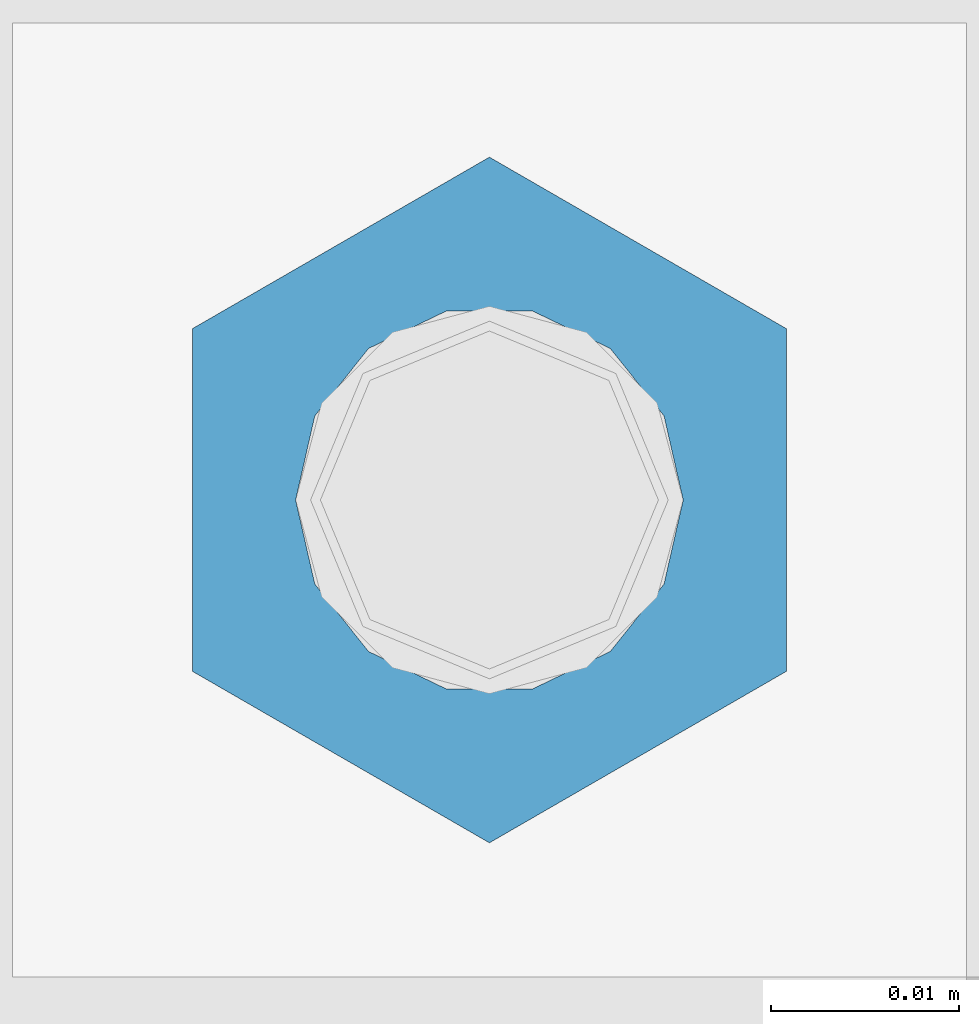
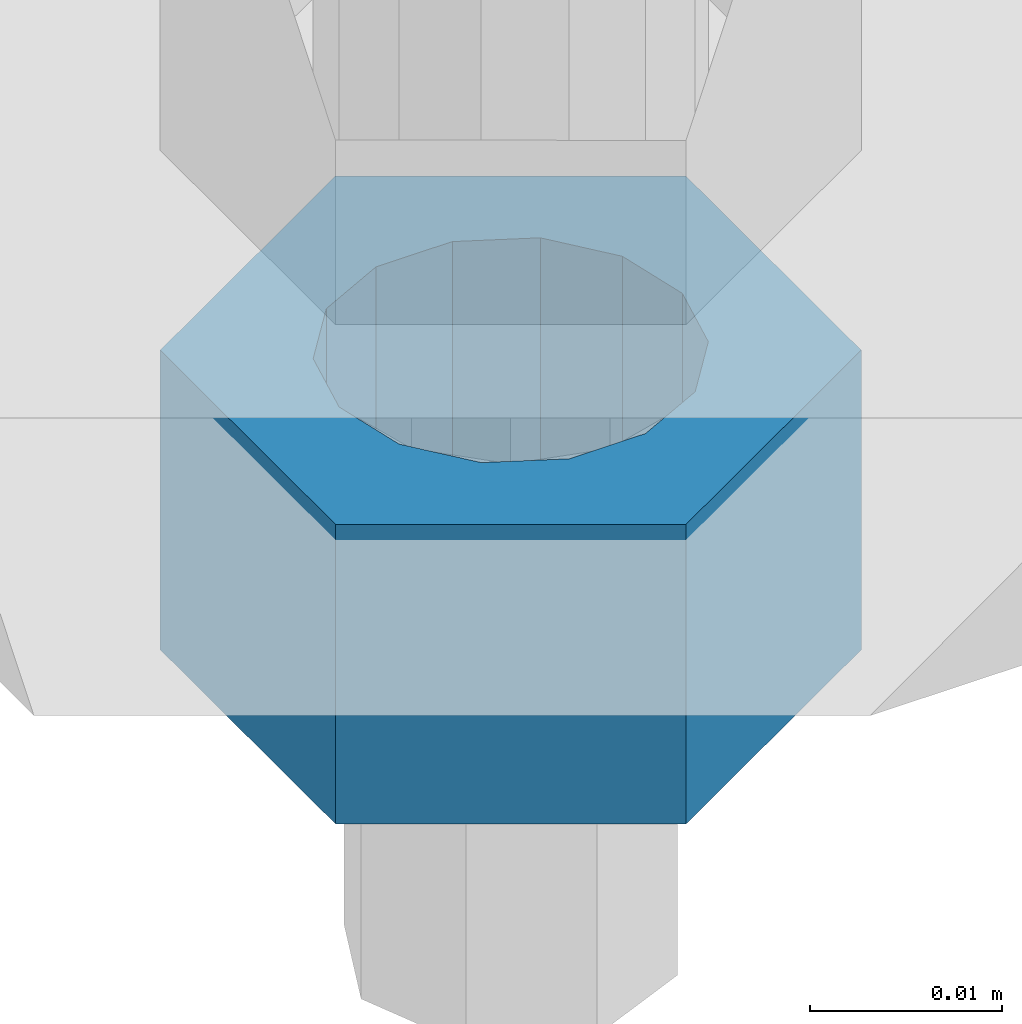
# One storey, part 1683 of 3843: 1 column, 1 element without a shape of its own.
"""IFC2X3 building model written with IfcOpenShell, lengths in millimetres."""

import ifcopenshell
import ifcopenshell.guid

model = None  # the IFC model being written
_history = None  # IfcOwnerHistory: only IFC2X3 demands one
_inside = {}  # id of a spatial element -> (the spatial element, [elements in it])
_under = {}  # id of a project, library or spatial element -> (it, [spatial elements below it])
_declared = {}  # id of a project -> (the project, [libraries it declares])
_typed = {}  # id of a type object -> (the type object, [elements of that type])
_made_of = {}  # id of a material, layer set ... -> (it, [elements and type objects made of it])


def new_model(schema):
    """Start an empty IFC model of exactly this schema.

    Asked for "IFC4X3", IfcOpenShell would pick the latest addendum, in which some entities
    have other attributes; the version numbers below select the first issue.
    IFC2X3 requires an IfcOwnerHistory on every rooted entity: one is made here for all.
    """
    global model, _history
    if schema == "IFC4X3":
        model = ifcopenshell.file(schema_version=(4, 3, 0, 0))
    else:
        model = ifcopenshell.file(schema=schema)
    _inside.clear()
    _under.clear()
    _declared.clear()
    _typed.clear()
    _made_of.clear()
    _history = None
    if model.schema == "IFC2X3":
        org = make("IfcOrganization", Name="unknown")
        user = make(
            "IfcPersonAndOrganization",
            ThePerson=make("IfcPerson", FamilyName="unknown"),
            TheOrganization=org,
        )
        app = make(
            "IfcApplication",
            ApplicationDeveloper=org,
            Version="unknown",
            ApplicationFullName="unknown",
            ApplicationIdentifier="unknown",
        )
        _history = make(
            "IfcOwnerHistory",
            OwningUser=user,
            OwningApplication=app,
            ChangeAction="ADDED",
            CreationDate=0,
        )
    return model


def make(cls, **values):
    """One entity of the class cls with the attributes given. An attribute that is None is left unset."""
    return model.create_entity(
        cls, **{name: value for name, value in values.items() if value is not None}
    )


def rooted(cls, **values):
    """An entity with a GlobalId (a new one), such as an element, a storey or a relation."""
    return make(cls, GlobalId=ifcopenshell.guid.new(), OwnerHistory=_history, **values)


def si_unit(unit_type, name, prefix=None):
    """IfcSIUnit, for example si_unit("LENGTHUNIT", "METRE", prefix="MILLI")."""
    return make("IfcSIUnit", UnitType=unit_type, Prefix=prefix, Name=name)


def assignment(units):
    """IfcUnitAssignment: the units of a project."""
    return None if units is None else make("IfcUnitAssignment", Units=units)


def point(xyz):
    """IfcCartesianPoint."""
    return None if xyz is None else make("IfcCartesianPoint", Coordinates=xyz)


def direction(xyz):
    """IfcDirection."""
    return None if xyz is None else make("IfcDirection", DirectionRatios=xyz)


def frame(location, z_axis=None, x_axis=None):
    """IfcAxis2Placement3D, a coordinate frame: its origin and axes. An axis left out is left unset."""
    return make(
        "IfcAxis2Placement3D",
        Location=point(location),
        Axis=direction(z_axis),
        RefDirection=direction(x_axis),
    )


def origin_with_axes():
    """The frame at (0, 0, 0) with the z axis (0, 0, 1) and the x axis (1, 0, 0) written out."""
    return frame((0.0, 0.0, 0.0), z_axis=(0.0, 0.0, 1.0), x_axis=(1.0, 0.0, 0.0))


def place(relative_to, where):
    """IfcLocalPlacement: puts the frame where relative to a parent placement (None: the world)."""
    return make(
        "IfcLocalPlacement", PlacementRelTo=relative_to, RelativePlacement=where
    )


def context(
    kind, dimensions, precision=None, world=None, true_north=None, identifier=None
):
    """IfcGeometricRepresentationContext, for example the 3D "Model" context."""
    return make(
        "IfcGeometricRepresentationContext",
        ContextIdentifier=identifier,
        ContextType=kind,
        CoordinateSpaceDimension=dimensions,
        Precision=precision,
        WorldCoordinateSystem=world,
        TrueNorth=true_north,
    )


def subcontext(parent, identifier, kind, view, scale=None):
    """IfcGeometricRepresentationSubContext, for example "Body" below "Model"."""
    return make(
        "IfcGeometricRepresentationSubContext",
        ContextIdentifier=identifier,
        ContextType=kind,
        ParentContext=parent,
        TargetScale=scale,
        TargetView=view,
    )


def project(units=None, contexts=None):
    """IfcProject with its units and contexts."""
    return rooted(
        "IfcProject",
        Name="project",
        RepresentationContexts=contexts,
        UnitsInContext=assignment(units),
    )


def spatial(cls, under=None, at=None, **own):
    """A site, building, storey or space (cls), placed at a placement, below another one or the project."""
    s = rooted(cls, ObjectPlacement=at, **own)
    if under is not None:
        _under.setdefault(under.id(), (under, []))[1].append(s)
    return s


def faces_of(points, faces, orient=None, outer=None):
    """IfcFace entities. A face is a list of loops; a loop is a list of indices into points, from 0.

    orient and outer hold one flag for each loop. By default every Orientation is true, the
    first loop of a face is its IfcFaceOuterBound and the others are IfcFaceBound.
    """
    made = []
    for i, loops in enumerate(faces):
        bounds = []
        for j, loop in enumerate(loops):
            is_outer = j == 0 if outer is None else outer[i][j]
            bounds.append(
                make(
                    "IfcFaceOuterBound" if is_outer else "IfcFaceBound",
                    Bound=make("IfcPolyLoop", Polygon=[points[k] for k in loop]),
                    Orientation=True if orient is None else orient[i][j],
                )
            )
        made.append(make("IfcFace", Bounds=bounds))
    return made


def faceted_brep(points, faces, orient=None, outer=None, voids=None):
    """IfcFacetedBrep: a solid bounded by flat faces; with voids (closed shells), ...WithVoids."""
    shared = [point(p) for p in points]
    hull = make("IfcClosedShell", CfsFaces=faces_of(shared, faces, orient, outer))
    if voids is None:
        return make("IfcFacetedBrep", Outer=hull)
    return make(
        "IfcFacetedBrepWithVoids",
        Outer=hull,
        Voids=[
            make(cls, CfsFaces=faces_of(shared, fs, o, b)) for cls, fs, o, b in voids
        ],
    )


def shape(context_of_items, identifier, shape_type, items):
    """IfcShapeRepresentation: the items that make up one representation, for example the "Body"."""
    return make(
        "IfcShapeRepresentation",
        ContextOfItems=context_of_items,
        RepresentationIdentifier=identifier,
        RepresentationType=shape_type,
        Items=items,
    )


def material(Name=None, Category=None):
    """IfcMaterial."""
    return make("IfcMaterial", Name=Name, Category=Category)


def made_of(thing, what):
    """Note that an element or type object is made of a material, layer set ...; save() writes the relation."""
    if what is not None:
        _made_of.setdefault(what.id(), (what, []))[1].append(thing)
    return thing


def type_object(cls, material=None, **own):
    """A type object (cls), such as IfcWallType, which elements share."""
    return made_of(rooted(cls, **own), material)


def element(
    cls,
    number,
    at=None,
    inside=None,
    cuts=None,
    type_object=None,
    material=None,
    context=None,
    identifier="Body",
    shape_type=None,
    held_by="IfcProductDefinitionShape",
    body=None,
    shapes=None,
    **own,
):
    """One element of the class cls, such as IfcWall. Its Tag is "e" and its number.

    at: its placement. inside: the storey or other place that contains it. cuts: it is an
    opening in that element (IfcRelVoidsElement). A single representation is given by context,
    identifier, shape_type and body (its items); several are given by shapes. held_by: the class
    of the entity that holds the representations. save() writes the other relations.
    """
    e = rooted(cls, Tag="e%d" % number, ObjectPlacement=at, **own)
    if body is not None:
        shapes = [shape(context, identifier, shape_type, body)]
    if shapes is not None:
        e.Representation = make(held_by, Representations=shapes)
    if inside is not None:
        _inside.setdefault(inside.id(), (inside, []))[1].append(e)
    if cuts is not None:
        rooted(
            "IfcRelVoidsElement", RelatingBuildingElement=cuts, RelatedOpeningElement=e
        )
    if type_object is not None:
        _typed.setdefault(type_object.id(), (type_object, []))[1].append(e)
    return made_of(e, material)


def aggregate(whole, parts):
    """IfcRelAggregates: a whole, such as a stair, and the parts it consists of."""
    return rooted("IfcRelAggregates", RelatingObject=whole, RelatedObjects=parts)


def save(model, path):
    """Write the relations noted so far, then the file.

    IfcRelAggregates (storeys below a building ...), IfcRelContainedInSpatialStructure (elements
    in a storey), IfcRelDefinesByType, IfcRelAssociatesMaterial and IfcRelDeclares: one each for
    every whole, place, type object, material and project.
    """
    for whole, parts in _under.values():
        aggregate(whole, parts)
    for where, things in _inside.values():
        rooted(
            "IfcRelContainedInSpatialStructure",
            RelatedElements=things,
            RelatingStructure=where,
        )
    for kind, things in _typed.values():
        rooted("IfcRelDefinesByType", RelatedObjects=things, RelatingType=kind)
    for what, things in _made_of.values():
        rooted("IfcRelAssociatesMaterial", RelatedObjects=things, RelatingMaterial=what)
    for by, libraries in _declared.values():
        rooted("IfcRelDeclares", RelatingContext=by, RelatedDefinitions=libraries)
    model.write(path)


model = new_model("IFC2X3")

# Units and contexts
model_context = context("Model", 3, precision=1e-05, world=origin_with_axes())
body_context = subcontext(model_context, "Body", "Model", "MODEL_VIEW")
ifc_project = project(units=[si_unit("LENGTHUNIT", "METRE", prefix="MILLI"), si_unit("AREAUNIT", "SQUARE_METRE"), si_unit("VOLUMEUNIT", "CUBIC_METRE"), si_unit("MASSUNIT", "GRAM", prefix="KILO"), si_unit("TIMEUNIT", "SECOND"), si_unit("PLANEANGLEUNIT", "RADIAN"), si_unit("SOLIDANGLEUNIT", "STERADIAN"), si_unit("THERMODYNAMICTEMPERATUREUNIT", "DEGREE_CELSIUS"), si_unit("LUMINOUSINTENSITYUNIT", "LUMEN")], contexts=[model_context])

# Site, building, storey
site_placement = place(None, origin_with_axes())
site = spatial("IfcSite", under=ifc_project, at=site_placement, CompositionType="ELEMENT")
building_placement = place(site_placement, origin_with_axes())
building = spatial("IfcBuilding", under=site, at=building_placement, Name="Undefined", CompositionType="ELEMENT")
storey_placement = place(building_placement, origin_with_axes())
storey = spatial("IfcBuildingStorey", under=building, at=storey_placement, Name="Undefined", CompositionType="ELEMENT", Elevation=0.0)

# Assembly, column
assembly_placement = place(storey_placement, origin_with_axes())
assembly = element("IfcElementAssembly", 1, at=assembly_placement, inside=storey, Name="TEMPLATE", AssemblyPlace="NOTDEFINED", PredefinedType="RIGID_FRAME")
ifc_material = material(Name="STEEL/A36")
column_type = type_object("IfcColumnType", Name="3/4_HEAVY_HEX_NUT", PredefinedType="NOTDEFINED")
column_placement = place(assembly_placement, frame((38744.525, 58991.5, 29756.1), z_axis=(-1.0, 0.0, 0.0), x_axis=(0.0, 0.0, -1.0)))
column = element("IfcColumn", 2, at=column_placement, type_object=column_type, material=ifc_material, Name="NUT", ObjectType="3/4_HEAVY_HEX_NUT", context=body_context, shape_type="Brep", body=[
    faceted_brep([(0.0, -18.2600002288818, 0.0), (0.0, -9.13000011444092, -15.8100004196167), (19.0500000000029, -9.13000011444092, -15.8100004196167), (19.0500000000029, -18.2600002288818, 0.0), (0.0, 9.13000011444092, -15.8100004196167), (19.0500000000029, 9.13000011444092, -15.8100004196167), (0.0, 18.2600002288818, 0.0), (19.0500000000029, 18.2600002288818, 0.0), (0.0, 9.13000011444092, 15.8100004196167), (19.0500000000029, 9.13000011444092, 15.8100004196167), (0.0, -9.13000011444092, 15.8100004196167), (19.0500000000029, -9.13000011444092, 15.8100004196167), (0.0, 0.0, 10.3199996948242), (0.0, 4.47768005527905, 9.29799844179797), (19.0500000000029, 4.47768005527905, 9.29799844179797), (19.0500000000029, 0.0, 10.3199996948242), (0.0, 8.06850066047627, 6.43441456490837), (19.0500000000029, 8.06850066047627, 6.43441456490837), (0.0, 10.0612557561908, 2.2964159705225), (19.0500000000029, 10.0612557561908, 2.2964159705225), (0.0, 10.0612557561908, -2.2964159705225), (19.0500000000029, 10.0612557561908, -2.2964159705225), (0.0, 8.06850066047627, -6.43441456490837), (19.0500000000029, 8.06850066047627, -6.43441456490837), (0.0, 4.47768005527905, -9.29799844179797), (19.0500000000029, 4.47768005527905, -9.29799844179797), (0.0, 0.0, -10.3199996948242), (19.0500000000029, 0.0, -10.3199996948242), (0.0, -4.47768005527905, -9.29799844179797), (19.0500000000029, -4.47768005527905, -9.29799844179797), (0.0, -8.06850066047627, -6.43441456490837), (19.0500000000029, -8.06850066047627, -6.43441456490837), (0.0, -10.0612557561908, -2.2964159705225), (19.0500000000029, -10.0612557561908, -2.2964159705225), (0.0, -10.0612557561908, 2.2964159705225), (19.0500000000029, -10.0612557561908, 2.2964159705225), (0.0, -8.06850066047627, 6.43441456490837), (19.0500000000029, -8.06850066047627, 6.43441456490837), (0.0, -4.47768005527905, 9.29799844179797), (19.0500000000029, -4.47768005527905, 9.29799844179797)], [[[0, 1, 2, 3]], [[1, 4, 5, 2]], [[4, 6, 7, 5]], [[6, 8, 9, 7]], [[8, 10, 11, 9]], [[10, 0, 3, 11]], [[12, 13, 14, 15]], [[13, 16, 17, 14]], [[16, 18, 19, 17]], [[18, 20, 21, 19]], [[20, 22, 23, 21]], [[22, 24, 25, 23]], [[24, 26, 27, 25]], [[26, 28, 29, 27]], [[28, 30, 31, 29]], [[30, 32, 33, 31]], [[32, 34, 35, 33]], [[34, 36, 37, 35]], [[36, 38, 39, 37]], [[38, 12, 15, 39]], [[5, 7, 9, 11, 3, 2], [17, 19, 21, 23, 25, 27, 29, 31, 33, 35, 37, 39, 15, 14]], [[10, 8, 6, 4, 1, 0], [38, 36, 34, 32, 30, 28, 26, 24, 22, 20, 18, 16, 13, 12]]]),
])
aggregate(assembly, [column])

save(model, "model.ifc")
